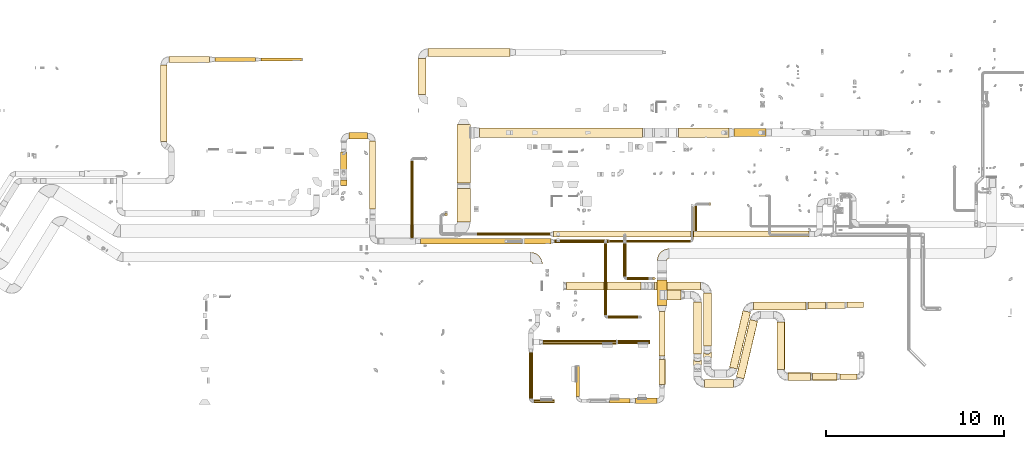
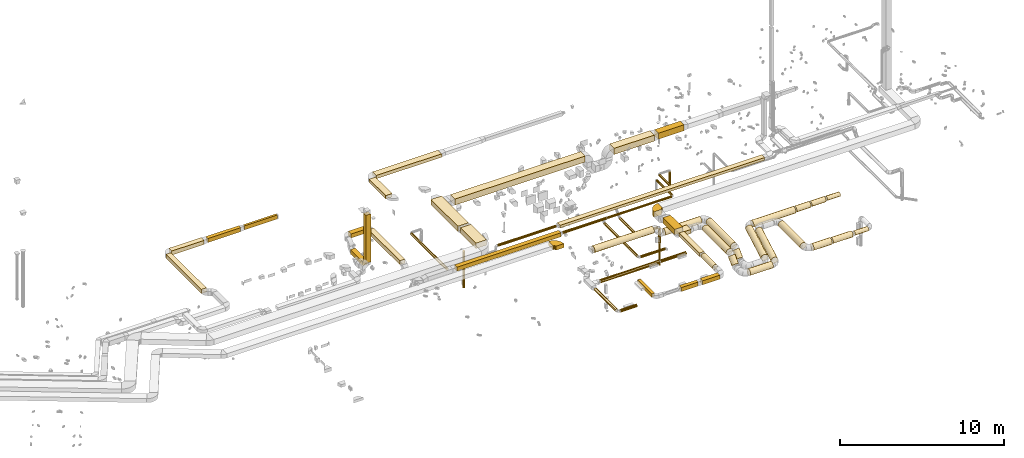
# One storey, part 2 of 97: 62 coverings.
"""IFC2X3 building model written with IfcOpenShell, lengths in millimetres."""

from ifc_helpers import new_model, entity, si_unit, converted_unit, derived_unit, direction, frame, frame_2d, origin, origin_2d_with_axis, place, context, subcontext, project, spatial, polyline, circle_curve, parameter, trimmed, segment, composite_curve, rectangle, circle, outline, extrude, element, save


model = new_model("IFC2X3")

# Units and contexts
model_context = context("Model", 3, precision=0.01, world=origin(), true_north=direction((6.12303176911189e-17, 1.0)))
body_context = subcontext(model_context, "Body", "Model", "MODEL_VIEW")
ifc_project = project(units=[si_unit("LENGTHUNIT", "METRE", prefix="MILLI"), si_unit("AREAUNIT", "SQUARE_METRE"), si_unit("VOLUMEUNIT", "CUBIC_METRE"), converted_unit("PLANEANGLEUNIT", "DEGREE", entity("IfcRatioMeasure", 0.0174532925199433), si_unit("PLANEANGLEUNIT", "RADIAN"), dimensions=[0, 0, 0, 0, 0, 0, 0]), si_unit("MASSUNIT", "GRAM", prefix="KILO"), derived_unit("MASSDENSITYUNIT", [(si_unit("MASSUNIT", "GRAM", prefix="KILO"), 1), (si_unit("LENGTHUNIT", "METRE"), -3)]), derived_unit("MOMENTOFINERTIAUNIT", [(si_unit("LENGTHUNIT", "METRE"), 4)]), si_unit("TIMEUNIT", "SECOND"), si_unit("FREQUENCYUNIT", "HERTZ"), si_unit("THERMODYNAMICTEMPERATUREUNIT", "DEGREE_CELSIUS"), derived_unit("THERMALTRANSMITTANCEUNIT", [(si_unit("MASSUNIT", "GRAM", prefix="KILO"), 1), (si_unit("THERMODYNAMICTEMPERATUREUNIT", "KELVIN"), -1), (si_unit("TIMEUNIT", "SECOND"), -3)]), derived_unit("VOLUMETRICFLOWRATEUNIT", [(si_unit("LENGTHUNIT", "METRE"), 3), (si_unit("TIMEUNIT", "SECOND"), -1)]), derived_unit("MASSFLOWRATEUNIT", [(si_unit("MASSUNIT", "GRAM", prefix="KILO"), 1), (si_unit("TIMEUNIT", "SECOND"), -1)]), derived_unit("ROTATIONALFREQUENCYUNIT", [(si_unit("TIMEUNIT", "SECOND"), -1)]), si_unit("ELECTRICCURRENTUNIT", "AMPERE"), si_unit("ELECTRICVOLTAGEUNIT", "VOLT"), si_unit("POWERUNIT", "WATT"), si_unit("FORCEUNIT", "NEWTON", prefix="KILO"), si_unit("ILLUMINANCEUNIT", "LUX"), si_unit("LUMINOUSFLUXUNIT", "LUMEN"), si_unit("LUMINOUSINTENSITYUNIT", "CANDELA"), derived_unit("USERDEFINED", [(si_unit("MASSUNIT", "GRAM", prefix="KILO"), -1), (si_unit("LENGTHUNIT", "METRE"), -2), (si_unit("TIMEUNIT", "SECOND"), 3), (si_unit("LUMINOUSFLUXUNIT", "LUMEN"), 1)]), derived_unit("LINEARVELOCITYUNIT", [(si_unit("LENGTHUNIT", "METRE"), 1), (si_unit("TIMEUNIT", "SECOND"), -1)]), si_unit("PRESSUREUNIT", "PASCAL"), derived_unit("USERDEFINED", [(si_unit("LENGTHUNIT", "METRE"), -2), (si_unit("MASSUNIT", "GRAM", prefix="KILO"), 1), (si_unit("TIMEUNIT", "SECOND"), -2)]), derived_unit("LINEARFORCEUNIT", [(si_unit("MASSUNIT", "GRAM", prefix="KILO"), 1), (si_unit("LENGTHUNIT", "METRE"), 1), (si_unit("TIMEUNIT", "SECOND"), -2), (si_unit("LENGTHUNIT", "METRE"), -1)]), derived_unit("PLANARFORCEUNIT", [(si_unit("MASSUNIT", "GRAM", prefix="KILO"), 1), (si_unit("LENGTHUNIT", "METRE"), 1), (si_unit("TIMEUNIT", "SECOND"), -2), (si_unit("LENGTHUNIT", "METRE"), -2)])], contexts=[model_context])

# Site, building, storey
site_placement = place(None, origin())
site = spatial("IfcSite", under=ifc_project, at=site_placement, CompositionType="ELEMENT")
building_placement = place(site_placement, origin())
building = spatial("IfcBuilding", under=site, at=building_placement, CompositionType="ELEMENT")
storey_placement = place(building_placement, frame((0.0, 0.0, -4900.0)))
storey = spatial("IfcBuildingStorey", under=building, at=storey_placement, CompositionType="ELEMENT", Elevation=-4900.0)

# Coverings
covering_1_placement = place(storey_placement, frame((49048.06, 6496.49, 3373.4)))
element("IfcCovering", 1, at=covering_1_placement, inside=storey, PredefinedType="INSULATION", context=body_context, shape_type="SweptSolid", body=[
    extrude(circle(Radius=225.0, at=origin_2d_with_axis()), frame((0.0, 226.6, 226.6), z_axis=(1.0, 0.0, 0.0), x_axis=(0.0, -1.0, 0.0)), (0.0, 0.0, 1.0), 2566.03464522663),
])
covering_2_placement = place(storey_placement, frame((51787.5, 3340.82, 3373.4)))
element("IfcCovering", 2, at=covering_2_placement, inside=storey, PredefinedType="INSULATION", context=body_context, shape_type="SweptSolid", body=[
    extrude(circle(Radius=225.0, at=origin_2d_with_axis()), frame((226.6, 0.0, 226.6), z_axis=(0.0, 1.0, 0.0), x_axis=(1.0, 0.0, 0.0)), (0.0, 0.0, 1.0), 2982.26908799999),
])
covering_3_placement = place(storey_placement, frame((51787.5, 2481.6, 2906.46)))
element("IfcCovering", 3, at=covering_3_placement, inside=storey, PredefinedType="INSULATION", context=body_context, shape_type="SweptSolid", body=[
    extrude(circle(Radius=225.0, at=origin_2d_with_axis()), frame((226.6, 160.69, 160.69), z_axis=(0.0, 0.707106781186522, 0.707106781186573), x_axis=(1.0, 0.0, 0.0)), (0.0, 0.0, 1.0), 587.867965644058),
])
covering_4_placement = place(storey_placement, frame((53252.84, 2052.59, 2723.4)))
element("IfcCovering", 4, at=covering_4_placement, inside=storey, PredefinedType="INSULATION", context=body_context, shape_type="SweptSolid", body=[
    extrude(circle(Radius=225.0, at=origin_2d_with_axis()), frame((220.54, 53.45, 226.6), z_axis=(0.230466234443146, 0.97308032288275, 0.0), x_axis=(-0.97308032288275, 0.230466234443146, 0.0)), (0.0, 0.0, 1.0), 3272.98056764663),
])
covering_5_placement = place(storey_placement, frame((59863.39, 5521.63, 2798.4)))
element("IfcCovering", 5, at=covering_5_placement, inside=storey, PredefinedType="INSULATION", context=body_context, shape_type="SweptSolid", body=[
    extrude(circle(Radius=150.0, at=origin_2d_with_axis()), frame((0.0, 151.6, 151.6), z_axis=(1.0, 0.0, 0.0), x_axis=(0.0, 1.0, 0.0)), (0.0, 0.0, 1.0), 925.254693962172),
])
covering_6_placement = place(storey_placement, frame((54616.92, 5372.13, 2723.4)))
element("IfcCovering", 6, at=covering_6_placement, inside=storey, PredefinedType="INSULATION", context=body_context, shape_type="SweptSolid", body=[
    extrude(circle(Radius=225.0, at=origin_2d_with_axis()), frame((0.0, 226.6, 226.6), z_axis=(1.0, 0.0, 0.0), x_axis=(0.0, 1.0, 0.0)), (0.0, 0.0, 1.0), 2951.06360611809),
])
covering_7_placement = place(storey_placement, frame((57659.98, 5416.63, 2745.9)))
element("IfcCovering", 7, at=covering_7_placement, inside=storey, PredefinedType="INSULATION", context=body_context, shape_type="SweptSolid", body=[
    extrude(circle(Radius=202.5, at=origin_2d_with_axis()), frame((0.0, 204.1, 204.1), z_axis=(1.0, 0.0, 0.0), x_axis=(0.0, 1.0, 0.0)), (0.0, 0.0, 1.0), 999.633099706871),
])
covering_8_placement = place(storey_placement, frame((58744.62, 5457.13, 2765.9)))
element("IfcCovering", 8, at=covering_8_placement, inside=storey, PredefinedType="INSULATION", context=body_context, shape_type="SweptSolid", body=[
    extrude(circle(Radius=182.5, at=origin_2d_with_axis()), frame((0.0, 184.1, 184.1), z_axis=(1.0, 0.0, 0.0), x_axis=(0.0, 1.0, 0.0)), (0.0, 0.0, 1.0), 999.769934937476),
])
covering_9_placement = place(storey_placement, frame((41983.0, 408.86, 3943.4)))
element("IfcCovering", 9, at=covering_9_placement, inside=storey, PredefinedType="INSULATION", context=body_context, shape_type="SweptSolid", body=[
    extrude(circle(Radius=105.0, at=origin_2d_with_axis()), frame((106.6, 0.0, 106.6), z_axis=(0.0, 1.0, 0.0), x_axis=(1.0, 0.0, 0.0)), (0.0, 0.0, 1.0), 2573.12127075),
])
covering_10_placement = place(storey_placement, frame((42249.6, 142.27, 3943.4)))
element("IfcCovering", 10, at=covering_10_placement, inside=storey, PredefinedType="INSULATION", context=body_context, shape_type="SweptSolid", body=[
    extrude(circle(Radius=105.0, at=origin_2d_with_axis()), frame((0.0, 106.6, 106.6), z_axis=(1.0, 0.0, 0.0), x_axis=(0.0, 1.0, 0.0)), (0.0, 0.0, 1.0), 1160.00000000006),
])
covering_11_placement = place(storey_placement, frame((46979.14, 3466.94, 3943.4)))
element("IfcCovering", 11, at=covering_11_placement, inside=storey, PredefinedType="INSULATION", context=body_context, shape_type="SweptSolid", body=[
    extrude(circle(Radius=105.0, at=origin_2d_with_axis()), frame((0.0, 106.6, 106.6), z_axis=(1.0, 0.0, 0.0), x_axis=(0.0, 1.0, 0.0)), (0.0, 0.0, 1.0), 1819.13111635832),
])
covering_12_placement = place(storey_placement, frame((42764.91, 3446.94, 3923.4)))
element("IfcCovering", 12, at=covering_12_placement, inside=storey, PredefinedType="INSULATION", context=body_context, shape_type="SweptSolid", body=[
    extrude(circle(Radius=125.0, at=origin_2d_with_axis()), frame((0.0, 126.6, 126.6), z_axis=(1.0, 0.0, 0.0), x_axis=(0.0, 1.0, 0.0)), (0.0, 0.0, 1.0), 4129.2321745),
])
covering_13_placement = place(storey_placement, frame((37934.51, 10320.01, 4075.0)))
element("IfcCovering", 13, at=covering_13_placement, inside=storey, PredefinedType="INSULATION", context=body_context, shape_type="SweptSolid", body=[
    extrude(rectangle(XDim=1895.67384788931, YDim=750.000000000003, at=origin_2d_with_axis()), frame((375.0, 947.84, 0.0), z_axis=(0.0, 0.0, 1.0), x_axis=(0.0, 1.0, 0.0)), (0.0, 0.0, 1.0), 400.0),
])
covering_14_placement = place(storey_placement, frame((37934.51, 12520.62, 4000.0)))
element("IfcCovering", 14, at=covering_14_placement, inside=storey, PredefinedType="INSULATION", context=body_context, shape_type="SweptSolid", body=[
    extrude(rectangle(XDim=3278.30706856473, YDim=750.000000000003, at=origin_2d_with_axis()), frame((375.0, 1639.15, 0.0), z_axis=(0.0, 0.0, 1.0), x_axis=(0.0, 1.0, 0.0)), (0.0, 0.0, 1.0), 400.0),
])
covering_15_placement = place(storey_placement, frame((35739.51, 17493.43, 4175.0)))
element("IfcCovering", 15, at=covering_15_placement, inside=storey, PredefinedType="INSULATION", context=body_context, shape_type="SweptSolid", body=[
    extrude(rectangle(XDim=2020.37256000016, YDim=450.000000000002, at=origin_2d_with_axis()), frame((225.0, 1010.19, 0.0), z_axis=(0.0, 0.0, 1.0), x_axis=(0.0, -1.0, 0.0)), (0.0, 0.0, 1.0), 250.0),
])
covering_16_placement = place(storey_placement, frame((36314.51, 19638.8, 4175.0)))
element("IfcCovering", 16, at=covering_16_placement, inside=storey, PredefinedType="INSULATION", context=body_context, shape_type="SweptSolid", body=[
    extrude(rectangle(XDim=4599.07089300011, YDim=450.000000000002, at=origin_2d_with_axis()), frame((2299.54, 225.0, 0.0)), (0.0, 0.0, 1.0), 250.0),
])
covering_17_placement = place(storey_placement, frame((21264.2, 14853.13, 3825.0)))
element("IfcCovering", 17, at=covering_17_placement, inside=storey, PredefinedType="INSULATION", context=body_context, shape_type="SweptSolid", body=[
    extrude(rectangle(XDim=4310.31577104467, YDim=349.999999999998, at=origin_2d_with_axis()), frame((175.0, 2155.16, 0.0), z_axis=(0.0, 0.0, 1.0), x_axis=(0.0, 1.0, 0.0)), (0.0, 0.0, 1.0), 300.0),
])
covering_18_placement = place(storey_placement, frame((26914.66, 19388.45, 3825.0)))
element("IfcCovering", 18, at=covering_18_placement, inside=storey, PredefinedType="INSULATION", context=body_context, shape_type="SweptSolid", body=[
    extrude(rectangle(XDim=2300.0, YDim=150.000000000001, at=origin_2d_with_axis()), frame((1150.0, 75.0, 0.0)), (0.0, 0.0, 1.0), 300.0),
])
covering_19_placement = place(storey_placement, frame((21739.2, 19288.45, 3825.0)))
element("IfcCovering", 19, at=covering_19_placement, inside=storey, PredefinedType="INSULATION", context=body_context, shape_type="SweptSolid", body=[
    extrude(rectangle(XDim=2275.06644000006, YDim=350.000000000001, at=origin_2d_with_axis()), frame((1137.53, 175.0, 0.0)), (0.0, 0.0, 1.0), 300.0),
])
covering_20_placement = place(storey_placement, frame((24314.26, 19338.45, 3825.0)))
element("IfcCovering", 20, at=covering_20_placement, inside=storey, PredefinedType="INSULATION", context=body_context, shape_type="SweptSolid", body=[
    extrude(rectangle(XDim=2300.39426999994, YDim=250.000000000002, at=origin_2d_with_axis()), frame((1150.2, 125.0, 0.0)), (0.0, 0.0, 1.0), 300.0),
])
covering_21_placement = place(storey_placement, frame((31385.12, 12374.99, 4014.99)))
element("IfcCovering", 21, at=covering_21_placement, inside=storey, PredefinedType="INSULATION", context=body_context, shape_type="SweptSolid", body=[
    extrude(rectangle(XDim=300.000000000001, YDim=349.999999999999, at=origin_2d_with_axis()), frame((175.1, 150.0, 0.01), z_axis=(-2.94447184399149e-05, 0.0, 1.0), x_axis=(0.0, 1.0, 0.0)), (0.0, 0.0, 1.0), 3565.00004936891),
])
covering_22_placement = place(storey_placement, frame((31385.22, 12799.99, 3590.0)))
element("IfcCovering", 22, at=covering_22_placement, inside=storey, PredefinedType="INSULATION", context=body_context, shape_type="SweptSolid", body=[
    extrude(rectangle(XDim=1470.0000048997, YDim=349.999999999997, at=origin_2d_with_axis()), frame((175.0, 735.0, 0.0), z_axis=(0.0, 1.20820011890754e-08, 1.0), x_axis=(-5.17399198813751e-06, 1.0, -1.20820011892371e-08)), (0.0, 0.0, 1.0), 300.0),
])
covering_23_placement = place(storey_placement, frame((35887.72, 9095.01, 3850.0)))
element("IfcCovering", 23, at=covering_23_placement, inside=storey, PredefinedType="INSULATION", context=body_context, shape_type="SweptSolid", body=[
    extrude(rectangle(XDim=7324.49625800007, YDim=299.999999999999, at=origin_2d_with_axis()), frame((3662.25, 150.0, 0.0)), (0.0, 0.0, 1.0), 300.0),
])
covering_24_placement = place(storey_placement, frame((43412.22, 9155.91, 3910.9)))
element("IfcCovering", 24, at=covering_24_placement, inside=storey, PredefinedType="INSULATION", context=body_context, shape_type="SweptSolid", body=[
    extrude(circle(Radius=87.5, at=origin_2d_with_axis()), frame((0.0, 89.1, 89.1), z_axis=(1.0, 0.0, 0.0), x_axis=(0.0, -1.0, 0.0)), (0.0, 0.0, 1.0), 3048.29595392129),
])
covering_25_placement = place(storey_placement, frame((46485.51, 9168.41, 3923.4)))
element("IfcCovering", 25, at=covering_25_placement, inside=storey, PredefinedType="INSULATION", context=body_context, shape_type="SweptSolid", body=[
    extrude(outline(polyline([(-9.79, -74.36), (9.79, -74.36), (28.7, -69.29), (45.66, -59.5), (59.5, -45.66), (69.29, -28.7), (74.36, -9.79), (74.36, 9.79), (69.29, 28.7), (59.5, 45.66), (45.66, 59.5), (28.7, 69.29), (9.79, 74.36), (-9.79, 74.36), (-28.7, 69.29), (-45.66, 59.5), (-59.5, 45.66), (-69.29, 28.7), (-74.36, 9.79), (-74.36, -9.79), (-69.29, -28.7), (-59.5, -45.66), (-45.66, -59.5), (-28.7, -69.29), (-9.79, -74.36)])), frame((0.0, 76.6, 76.6), z_axis=(1.0, 0.0, -3.05662962933163e-09), x_axis=(-3.03042399584651e-09, 0.130526192220057, -0.99144486137381)), (0.0, 0.0, 1.0), 4568.00816944938),
])
covering_26_placement = place(storey_placement, frame((35310.54, 9415.01, 3890.9)))
element("IfcCovering", 26, at=covering_26_placement, inside=storey, PredefinedType="INSULATION", context=body_context, shape_type="SweptSolid", body=[
    extrude(circle(Radius=87.5, at=origin_2d_with_axis()), frame((89.1, 0.0, 89.1), z_axis=(0.0, 1.0, 0.0), x_axis=(-1.0, 0.0, 0.0)), (0.0, 0.0, 1.0), 4352.10168621019),
])
covering_27_placement = place(storey_placement, frame((46200.29, 5098.33, 3650.9)))
element("IfcCovering", 27, at=covering_27_placement, inside=storey, PredefinedType="INSULATION", context=body_context, shape_type="SweptSolid", body=[
    extrude(circle(Radius=87.5, at=origin_2d_with_axis()), frame((89.1, 0.0, 89.1), z_axis=(0.0, 1.0, 0.0), x_axis=(1.0, 0.0, 0.0)), (0.0, 0.0, 1.0), 4021.67244635073),
])
covering_28_placement = place(storey_placement, frame((46414.39, 4884.24, 3650.9)))
element("IfcCovering", 28, at=covering_28_placement, inside=storey, PredefinedType="INSULATION", context=body_context, shape_type="SweptSolid", body=[
    extrude(circle(Radius=87.5, at=origin_2d_with_axis()), frame((0.0, 89.1, 89.1), z_axis=(1.0, 0.0, 0.0), x_axis=(0.0, 1.0, 0.0)), (0.0, 0.0, 1.0), 1709.99999999984),
])
covering_29_placement = place(storey_placement, frame((49188.6, 5628.36, 4000.0)))
element("IfcCovering", 29, at=covering_29_placement, inside=storey, PredefinedType="INSULATION", context=body_context, shape_type="SweptSolid", body=[
    extrude(rectangle(XDim=1446.47429187333, YDim=549.999999999996, at=origin_2d_with_axis()), frame((275.0, 723.24, 0.0), z_axis=(0.0, 0.0, 1.0), x_axis=(0.0, -1.0, 0.0)), (0.0, 0.0, 1.0), 400.0),
])
covering_30_placement = place(storey_placement, frame((49288.6, 2795.77, 4075.0)))
element("IfcCovering", 30, at=covering_30_placement, inside=storey, PredefinedType="INSULATION", context=body_context, shape_type="SweptSolid", body=[
    extrude(rectangle(XDim=2482.5949383323, YDim=350.000000000007, at=origin_2d_with_axis()), frame((175.0, 1241.3, 0.0), z_axis=(0.0, 1.38770222428781e-08, 1.0), x_axis=(0.0, -1.0, 1.38770222428781e-08)), (0.0, 0.0, 1.0), 250.0),
])
covering_31_placement = place(storey_placement, frame((49279.5, 1195.38, 4015.9)))
element("IfcCovering", 31, at=covering_31_placement, inside=storey, PredefinedType="INSULATION", context=body_context, shape_type="SweptSolid", body=[
    extrude(outline(polyline([(-23.82, -180.94), (23.82, -180.94), (69.84, -168.61), (111.1, -144.79), (144.79, -111.1), (168.61, -69.84), (180.94, -23.82), (180.94, 23.82), (168.61, 69.84), (144.79, 111.1), (111.1, 144.79), (69.84, 168.61), (23.82, 180.94), (-23.82, 180.94), (-69.84, 168.61), (-111.1, 144.79), (-144.79, 111.1), (-168.61, 69.84), (-180.94, 23.82), (-180.94, -23.82), (-168.61, -69.84), (-144.79, -111.1), (-111.1, -144.79), (-69.84, -168.61), (-23.82, -180.94)])), frame((184.1, 0.0, 184.1), z_axis=(0.0, 1.0, -8.03528565757798e-09), x_axis=(-0.130526192220056, -7.96654524278022e-09, -0.99144486137381)), (0.0, 0.0, 1.0), 1400.38555541775),
])
covering_32_placement = place(storey_placement, frame((47973.94, 123.87, 4050.0)))
element("IfcCovering", 32, at=covering_32_placement, inside=storey, PredefinedType="INSULATION", context=body_context, shape_type="SweptSolid", body=[
    extrude(rectangle(XDim=1214.65979800017, YDim=300.0, at=origin_2d_with_axis()), frame((607.33, 150.0, 0.0), z_axis=(0.0, 0.0, 1.0), x_axis=(-1.0, 0.0, 0.0)), (0.0, 0.0, 1.0), 300.0),
])
covering_33_placement = place(storey_placement, frame((46506.13, 148.87, 4050.0)))
element("IfcCovering", 33, at=covering_33_placement, inside=storey, PredefinedType="INSULATION", context=body_context, shape_type="SweptSolid", body=[
    extrude(rectangle(XDim=1167.81204199994, YDim=250.0, at=origin_2d_with_axis()), frame((583.91, 125.0, 0.0), z_axis=(0.0, 0.0, 1.0), x_axis=(-1.0, 0.0, 0.0)), (0.0, 0.0, 1.0), 300.0),
])
covering_34_placement = place(storey_placement, frame((44618.59, 498.87, 4075.0)))
element("IfcCovering", 34, at=covering_34_placement, inside=storey, PredefinedType="INSULATION", context=body_context, shape_type="SweptSolid", body=[
    extrude(rectangle(XDim=1718.27115999996, YDim=200.000000000007, at=origin_2d_with_axis()), frame((100.0, 859.14, 0.0), z_axis=(0.0, 0.0, 1.0), x_axis=(0.0, 1.0, 0.0)), (0.0, 0.0, 1.0), 250.0),
])
covering_35_placement = place(storey_placement, frame((49738.6, 5948.55, 3450.0)))
element("IfcCovering", 35, at=covering_35_placement, inside=storey, PredefinedType="INSULATION", context=body_context, shape_type="SweptSolid", body=[
    extrude(rectangle(XDim=797.245327746324, YDim=550.000000000001, at=origin_2d_with_axis()), frame((398.62, 275.0, 0.0)), (0.0, 0.0, 1.0), 300.0),
])
covering_36_placement = place(storey_placement, frame((51237.56, 2909.23, 3373.4)))
element("IfcCovering", 36, at=covering_36_placement, inside=storey, PredefinedType="INSULATION", context=body_context, shape_type="SweptSolid", body=[
    extrude(circle(Radius=225.0, at=origin_2d_with_axis()), frame((226.6, 0.0, 226.6), z_axis=(0.0, 1.0, 0.0), x_axis=(1.0, 0.0, 0.0)), (0.0, 0.0, 1.0), 2914.31457505077),
])
covering_37_placement = place(storey_placement, frame((51237.56, 2050.01, 2906.46)))
element("IfcCovering", 37, at=covering_37_placement, inside=storey, PredefinedType="INSULATION", context=body_context, shape_type="SweptSolid", body=[
    extrude(circle(Radius=225.0, at=origin_2d_with_axis()), frame((226.6, 160.69, 160.69), z_axis=(0.0, 0.707106781186546, 0.707106781186549), x_axis=(1.0, 0.0, 0.0)), (0.0, 0.0, 1.0), 587.867967804478),
])
covering_38_placement = place(storey_placement, frame((51864.16, 1022.13, 2723.4)))
element("IfcCovering", 38, at=covering_38_placement, inside=storey, PredefinedType="INSULATION", context=body_context, shape_type="SweptSolid", body=[
    extrude(circle(Radius=225.0, at=origin_2d_with_axis()), frame((0.0, 226.6, 226.6), z_axis=(1.0, 0.0, 0.0), x_axis=(0.0, 1.0, 0.0)), (0.0, 0.0, 1.0), 1604.59195470507),
])
covering_39_placement = place(storey_placement, frame((53637.44, 1503.09, 2723.4)))
element("IfcCovering", 39, at=covering_39_placement, inside=storey, PredefinedType="INSULATION", context=body_context, shape_type="SweptSolid", body=[
    extrude(circle(Radius=225.0, at=origin_2d_with_axis()), frame((220.54, 53.45, 226.6), z_axis=(0.230466228592691, 0.973080324268383, 0.0), x_axis=(0.973080324268383, -0.230466228592691, 0.0)), (0.0, 0.0, 1.0), 3323.4328894738),
])
covering_40_placement = place(storey_placement, frame((55917.39, 2026.52, 2723.4)))
element("IfcCovering", 40, at=covering_40_placement, inside=storey, PredefinedType="INSULATION", context=body_context, shape_type="SweptSolid", body=[
    extrude(circle(Radius=225.0, at=origin_2d_with_axis()), frame((226.6, 0.0, 226.6), z_axis=(0.0, 1.0, 0.0), x_axis=(1.0, 0.0, 0.0)), (0.0, 0.0, 1.0), 2671.80245293195),
])
covering_41_placement = place(storey_placement, frame((59484.61, 1474.92, 2798.4)))
element("IfcCovering", 41, at=covering_41_placement, inside=storey, PredefinedType="INSULATION", context=body_context, shape_type="SweptSolid", body=[
    extrude(circle(Radius=150.0, at=origin_2d_with_axis()), frame((0.0, 151.6, 151.6), z_axis=(1.0, 0.0, 0.0), x_axis=(0.0, 1.0, 0.0)), (0.0, 0.0, 1.0), 954.521669775234),
])
covering_42_placement = place(storey_placement, frame((56543.98, 1399.92, 2723.4)))
element("IfcCovering", 42, at=covering_42_placement, inside=storey, PredefinedType="INSULATION", context=body_context, shape_type="SweptSolid", body=[
    extrude(circle(Radius=225.0, at=origin_2d_with_axis()), frame((0.0, 226.6, 226.6), z_axis=(1.0, 0.0, 0.0), x_axis=(0.0, 1.0, 0.0)), (0.0, 0.0, 1.0), 1280.36323550003),
])
covering_43_placement = place(storey_placement, frame((57916.35, 1422.42, 2745.9)))
element("IfcCovering", 43, at=covering_43_placement, inside=storey, PredefinedType="INSULATION", context=body_context, shape_type="SweptSolid", body=[
    extrude(circle(Radius=202.5, at=origin_2d_with_axis()), frame((0.0, 204.1, 204.1), z_axis=(1.0, 0.0, 0.0), x_axis=(0.0, 1.0, 0.0)), (0.0, 0.0, 1.0), 1394.26236472474),
])
covering_44_placement = place(storey_placement, frame((51277.68, 9813.15, 4223.4)))
element("IfcCovering", 44, at=covering_44_placement, inside=storey, PredefinedType="INSULATION", context=body_context, shape_type="SweptSolid", body=[
    extrude(circle(Radius=75.0, at=origin_2d_with_axis()), frame((76.6, 0.0, 76.6), z_axis=(0.0, 1.0, 0.0), x_axis=(1.0, 0.0, 0.0)), (0.0, 0.0, 1.0), 1422.19842000003),
])
covering_45_placement = place(storey_placement, frame((52077.68, 11258.75, 3099.47)))
element("IfcCovering", 45, at=covering_45_placement, inside=storey, PredefinedType="INSULATION", context=body_context, shape_type="SweptSolid", body=[
    extrude(circle(Radius=75.0, at=origin_2d_with_axis()), frame((76.6, 76.6, 0.0)), (0.0, 0.0, 1.0), 1100.52558883259),
])
covering_46_placement = place(storey_placement, frame((47279.85, 7271.24, 3650.9)))
element("IfcCovering", 46, at=covering_46_placement, inside=storey, PredefinedType="INSULATION", context=body_context, shape_type="SweptSolid", body=[
    extrude(circle(Radius=87.5, at=origin_2d_with_axis()), frame((89.1, 0.0, 89.1), z_axis=(0.0, 1.0, 0.0), x_axis=(-1.0, 0.0, 0.0)), (0.0, 0.0, 1.0), 1845.13179470331),
])
covering_47_placement = place(storey_placement, frame((47493.94, 7057.14, 3650.9)))
element("IfcCovering", 47, at=covering_47_placement, inside=storey, PredefinedType="INSULATION", context=body_context, shape_type="SweptSolid", body=[
    extrude(circle(Radius=87.5, at=origin_2d_with_axis()), frame((0.0, 89.1, 89.1), z_axis=(1.0, 0.0, 0.0), x_axis=(0.0, 1.0, 0.0)), (0.0, 0.0, 1.0), 1380.43421999998),
])
covering_48_placement = place(storey_placement, frame((48910.28, 7057.14, 2565.0)))
element("IfcCovering", 48, at=covering_48_placement, inside=storey, PredefinedType="INSULATION", context=body_context, shape_type="SweptSolid", body=[
    extrude(circle(Radius=87.5, at=origin_2d_with_axis()), frame((89.1, 89.1, 0.0), z_axis=(0.0, 0.0, 1.0), x_axis=(0.0, 1.0, 0.0)), (0.0, 0.0, 1.0), 1050.0),
])
covering_49_placement = place(storey_placement, frame((48922.78, 7069.64, 905.0)))
element("IfcCovering", 49, at=covering_49_placement, inside=storey, PredefinedType="INSULATION", context=body_context, shape_type="SweptSolid", body=[
    extrude(circle(Radius=75.0, at=origin_2d_with_axis()), frame((76.6, 76.6, 0.0)), (0.0, 0.0, 1.0), 1634.99999999999),
])
covering_50_placement = place(storey_placement, frame((44090.33, 6496.49, 3823.4)))
element("IfcCovering", 50, at=covering_50_placement, inside=storey, PredefinedType="INSULATION", context=body_context, shape_type="SweptSolid", body=[
    extrude(circle(Radius=225.0, at=origin_2d_with_axis()), frame((0.0, 226.6, 226.6), z_axis=(1.0, 0.0, 0.0), x_axis=(0.0, 1.0, 0.0)), (0.0, 0.0, 1.0), 4176.36310262494),
])
covering_51_placement = place(storey_placement, frame((33013.7, 11052.57, 4150.0)))
element("IfcCovering", 51, at=covering_51_placement, inside=storey, PredefinedType="INSULATION", context=body_context, shape_type="SweptSolid", body=[
    extrude(rectangle(XDim=3816.61439284741, YDim=349.999999999998, at=origin_2d_with_axis()), frame((175.0, 1908.31, 0.0), z_axis=(0.0, 0.0, 1.0), x_axis=(0.0, -1.0, 0.0)), (0.0, 0.0, 1.0), 300.0),
])
covering_52_placement = place(storey_placement, frame((43355.69, 9468.15, 4225.0)))
element("IfcCovering", 52, at=covering_52_placement, inside=storey, PredefinedType="INSULATION", context=body_context, shape_type="SweptSolid", body=[
    extrude(rectangle(XDim=14374.123088, YDim=350.000000000001, at=origin_2d_with_axis()), frame((7187.06, 175.0, 0.0), z_axis=(0.0, 0.0, 1.0), x_axis=(-1.0, 0.0, 0.0)), (0.0, 0.0, 1.0), 200.0),
])
covering_53_placement = place(storey_placement, frame((39064.81, 9554.05, 4235.9)))
element("IfcCovering", 53, at=covering_53_placement, inside=storey, PredefinedType="INSULATION", context=body_context, shape_type="SweptSolid", body=[
    extrude(circle(Radius=87.5, at=origin_2d_with_axis()), frame((0.0, 89.1, 89.1), z_axis=(1.0, 0.0, 0.0), x_axis=(0.0, 1.0, 0.0)), (0.0, 0.0, 1.0), 4090.87691199999),
])
covering_54_placement = place(storey_placement, frame((37246.43, 10670.87, 1150.0)))
element("IfcCovering", 54, at=covering_54_placement, inside=storey, PredefinedType="INSULATION", context=body_context, shape_type="SweptSolid", body=[
    extrude(circle(Radius=75.0, at=origin_2d_with_axis()), frame((76.6, 76.6, 0.0), z_axis=(0.0, 0.0, 1.0), x_axis=(0.0, -1.0, 0.0)), (0.0, 0.0, 1.0), 1280.00007313086),
])
covering_55_placement = place(storey_placement, frame((37233.93, 10658.37, 2494.0)))
element("IfcCovering", 55, at=covering_55_placement, inside=storey, PredefinedType="INSULATION", context=body_context, shape_type="SweptSolid", body=[
    extrude(circle(Radius=87.5, at=origin_2d_with_axis()), frame((89.1, 89.1, 0.0), z_axis=(0.0, 0.0, 1.0), x_axis=(0.0, -1.0, 0.0)), (0.0, 0.0, 1.0), 1360.99992675),
])
covering_56_placement = place(storey_placement, frame((31860.22, 14994.18, 4150.0)))
element("IfcCovering", 56, at=covering_56_placement, inside=storey, PredefinedType="INSULATION", context=body_context, shape_type="SweptSolid", body=[
    extrude(rectangle(XDim=1028.47903642511, YDim=349.999999999998, at=origin_2d_with_axis()), frame((514.24, 175.0, 0.0), z_axis=(-1.53569181928049e-08, 0.0, 1.0), x_axis=(-1.0, 0.0, -1.53569181928049e-08)), (0.0, 0.0, 1.0), 300.0),
])
covering_57_placement = place(storey_placement, frame((39195.61, 15074.1, 3975.0)))
element("IfcCovering", 57, at=covering_57_placement, inside=storey, PredefinedType="INSULATION", context=body_context, shape_type="SweptSolid", body=[
    extrude(rectangle(XDim=9156.58602500004, YDim=550.000000000001, at=origin_2d_with_axis()), frame((4578.29, 275.0, 0.0)), (0.0, 0.0, 1.0), 450.0),
])
covering_58_placement = place(storey_placement, frame((50395.13, 15073.96, 3825.0)))
element("IfcCovering", 58, at=covering_58_placement, inside=storey, PredefinedType="INSULATION", context=body_context, shape_type="SweptSolid", body=[
    extrude(rectangle(XDim=2826.04187500001, YDim=550.000000000001, at=origin_2d_with_axis()), frame((1413.02, 275.0, 0.0), z_axis=(0.0, 0.0, 1.0), x_axis=(-1.0, 0.0, 0.0)), (0.0, 0.0, 1.0), 450.0),
])
covering_59_placement = place(storey_placement, frame((53521.17, 15123.96, 3825.0)))
element("IfcCovering", 59, at=covering_59_placement, inside=storey, PredefinedType="INSULATION", context=body_context, shape_type="SweptSolid", body=[
    extrude(rectangle(XDim=1794.33030025006, YDim=450.000000000002, at=origin_2d_with_axis()), frame((897.17, 225.0, 0.0)), (0.0, 0.0, 1.0), 450.0),
])
covering_60_placement = place(storey_placement, frame((51076.93, 9345.01, 3923.4)))
element("IfcCovering", 60, at=covering_60_placement, inside=storey, PredefinedType="INSULATION", context=body_context, shape_type="SweptSolid", body=[
    extrude(circle(Radius=75.0, at=origin_2d_with_axis()), frame((76.6, 0.0, 76.6), z_axis=(0.0, 1.0, 0.0), x_axis=(-1.0, 0.0, 0.0)), (0.0, 0.0, 1.0), 1820.00000000003),
])
covering_61_placement = place(storey_placement, frame((49187.0, 8148.77, 3780.0)))
element("IfcCovering", 61, at=covering_61_placement, inside=storey, PredefinedType="INSULATION", context=body_context, shape_type="SweptSolid", body=[
    extrude(outline(composite_curve([segment(polyline([(-200.0, 75.0), (-200.0, -475.0)]), True, "CONTINUOUS"), segment(trimmed(circle_curve(frame_2d((-200.0, 200.0), x_axis=(1.0, 0.0)), 675.0), [parameter(270.0)], [parameter(0.0)], True, "PARAMETER"), True, "CONTINUOUS"), segment(polyline([(475.0, 200.0), (-75.0, 200.0)]), True, "CONTINUOUS"), segment(trimmed(circle_curve(frame_2d((-200.0, 200.0), x_axis=(1.0, 0.0)), 125.0), [parameter(270.0)], [parameter(360.0)], True, "PARAMETER"), False, "CONTINUOUS")], self_intersect=False)), frame((476.6, 201.6, 0.0), z_axis=(0.0, 0.0, -1.0), x_axis=(0.0, 1.0, 0.0)), (0.0, 0.0, -1.0), 400.0),
])
covering_62_placement = place(storey_placement, frame((42061.0, 7948.29, 3900.0)))
element("IfcCovering", 62, at=covering_62_placement, inside=storey, PredefinedType="INSULATION", context=body_context, shape_type="SweptSolid", body=[
    extrude(outline(composite_curve([segment(polyline([(-200.0, 75.0), (-200.0, -475.0)]), True, "CONTINUOUS"), segment(trimmed(circle_curve(frame_2d((-200.0, 200.0), x_axis=(1.0, 0.0)), 675.0), [parameter(270.0)], [parameter(0.0)], True, "PARAMETER"), True, "CONTINUOUS"), segment(polyline([(475.0, 200.0), (-75.0, 200.0)]), True, "CONTINUOUS"), segment(trimmed(circle_curve(frame_2d((-200.0, 200.0), x_axis=(1.0, 0.0)), 125.0), [parameter(270.0)], [parameter(360.0)], True, "PARAMETER"), False, "CONTINUOUS")], self_intersect=False)), frame((201.6, 201.6, 0.0), z_axis=(0.0, 0.0, -1.0), x_axis=(1.0, 0.0, 0.0)), (0.0, 0.0, -1.0), 300.0),
])

save(model, "model.ifc")
